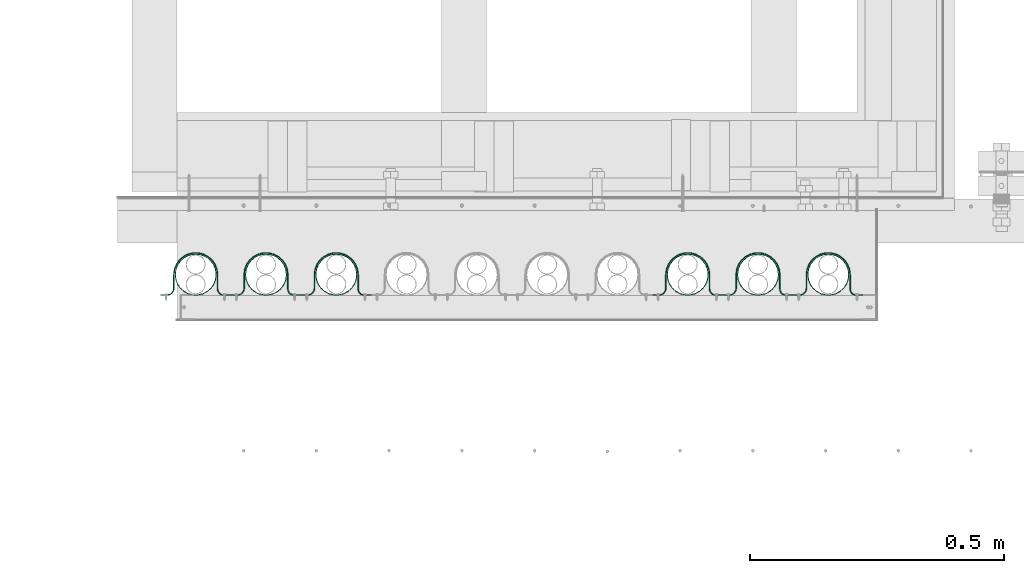
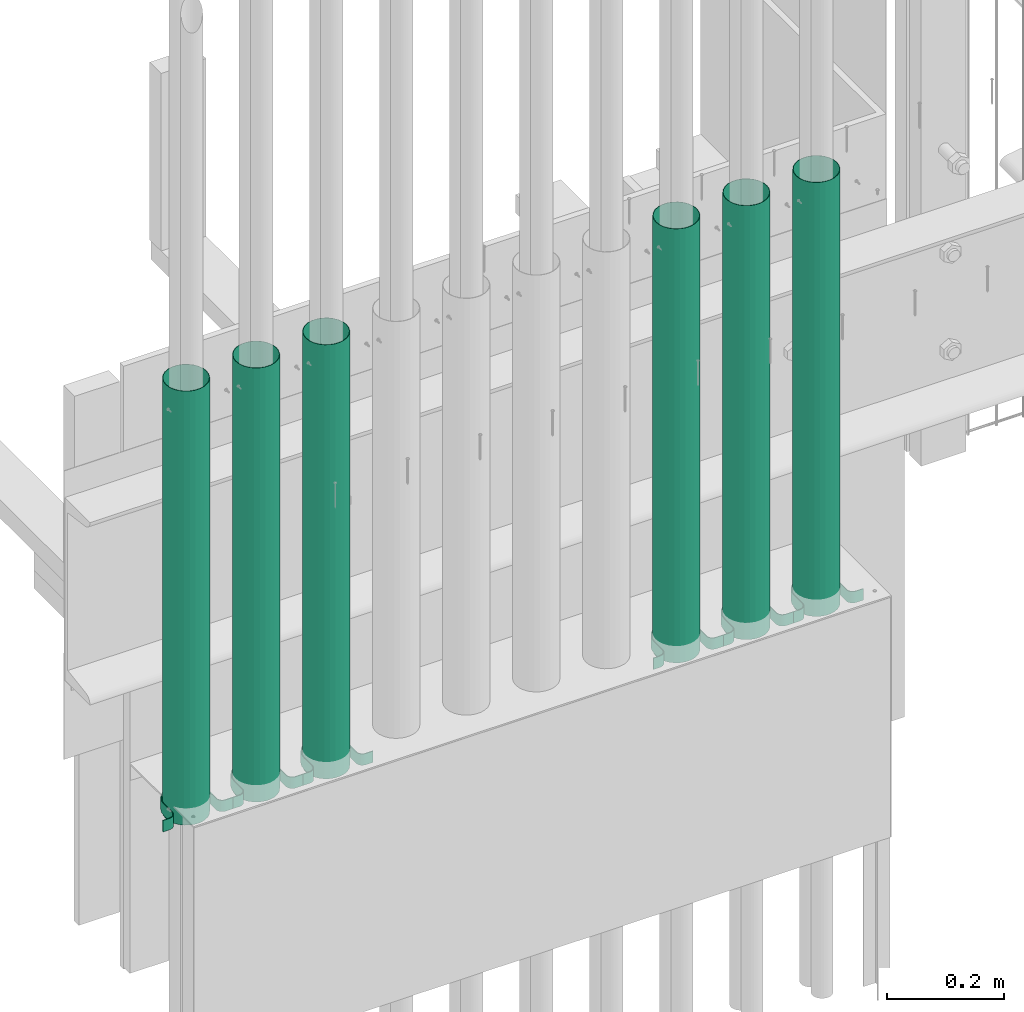
# One storey, part 7 of 44: 6 pipe fittings, 6 valves.
"""IFC4 building model written with IfcOpenShell, lengths in feet."""

from ifc_helpers import new_model, entity, si_unit, converted_unit, derived_unit, direction, frame, frame_2d, origin, place, context, subcontext, project, spatial, polyline, circle_curve, parameter, trimmed, segment, composite_curve, hollow_circle, outline, extrude, source, transform, mapped, material, type_object, type_shapes, element, save


model = new_model("IFC4")

# Units and contexts
model_context = context("Model", 3, precision=0.0001, world=origin(), true_north=direction((6.12303176911189e-17, 1.0)))
body_context = subcontext(model_context, "Body", "Model", "MODEL_VIEW")
ifc_project = project(units=[converted_unit("LENGTHUNIT", "FOOT", entity("IfcRatioMeasure", 0.3048), si_unit("LENGTHUNIT", "METRE"), dimensions=[1, 0, 0, 0, 0, 0, 0]), converted_unit("AREAUNIT", "SQUARE FOOT", entity("IfcRatioMeasure", 0.09290304), si_unit("AREAUNIT", "SQUARE_METRE"), dimensions=[2, 0, 0, 0, 0, 0, 0]), converted_unit("VOLUMEUNIT", "CUBIC FOOT", entity("IfcRatioMeasure", 0.028316846592), si_unit("VOLUMEUNIT", "CUBIC_METRE"), dimensions=[3, 0, 0, 0, 0, 0, 0]), converted_unit("PLANEANGLEUNIT", "DEGREE", entity("IfcRatioMeasure", 0.0174532925199433), si_unit("PLANEANGLEUNIT", "RADIAN"), dimensions=[0, 0, 0, 0, 0, 0, 0]), si_unit("MASSUNIT", "GRAM", prefix="KILO"), derived_unit("MASSDENSITYUNIT", [(si_unit("MASSUNIT", "GRAM", prefix="KILO"), 1), (si_unit("LENGTHUNIT", "METRE"), -3)]), derived_unit("MOMENTOFINERTIAUNIT", [(si_unit("LENGTHUNIT", "METRE"), 4)]), si_unit("TIMEUNIT", "SECOND"), si_unit("FREQUENCYUNIT", "HERTZ"), si_unit("THERMODYNAMICTEMPERATUREUNIT", "DEGREE_CELSIUS"), derived_unit("THERMALTRANSMITTANCEUNIT", [(si_unit("MASSUNIT", "GRAM", prefix="KILO"), 1), (si_unit("THERMODYNAMICTEMPERATUREUNIT", "KELVIN"), -1), (si_unit("TIMEUNIT", "SECOND"), -3)]), derived_unit("VOLUMETRICFLOWRATEUNIT", [(si_unit("LENGTHUNIT", "METRE"), 3), (si_unit("TIMEUNIT", "SECOND"), -1)]), si_unit("ELECTRICCURRENTUNIT", "AMPERE"), si_unit("ELECTRICVOLTAGEUNIT", "VOLT"), si_unit("POWERUNIT", "WATT"), si_unit("FORCEUNIT", "NEWTON"), si_unit("ILLUMINANCEUNIT", "LUX"), si_unit("LUMINOUSFLUXUNIT", "LUMEN"), si_unit("LUMINOUSINTENSITYUNIT", "CANDELA"), derived_unit("USERDEFINED", [(si_unit("MASSUNIT", "GRAM", prefix="KILO"), -1), (si_unit("LENGTHUNIT", "METRE"), -2), (si_unit("TIMEUNIT", "SECOND"), 3), (si_unit("LUMINOUSFLUXUNIT", "LUMEN"), 1)]), derived_unit("LINEARVELOCITYUNIT", [(si_unit("LENGTHUNIT", "METRE"), 1), (si_unit("TIMEUNIT", "SECOND"), -1)]), si_unit("PRESSUREUNIT", "PASCAL"), derived_unit("USERDEFINED", [(si_unit("LENGTHUNIT", "METRE"), -2), (si_unit("MASSUNIT", "GRAM", prefix="KILO"), 1), (si_unit("TIMEUNIT", "SECOND"), -2)]), derived_unit("LINEARFORCEUNIT", [(si_unit("MASSUNIT", "GRAM", prefix="KILO"), 1), (si_unit("LENGTHUNIT", "METRE"), 1), (si_unit("TIMEUNIT", "SECOND"), -2), (si_unit("LENGTHUNIT", "METRE"), -1)]), derived_unit("PLANARFORCEUNIT", [(si_unit("MASSUNIT", "GRAM", prefix="KILO"), 1), (si_unit("LENGTHUNIT", "METRE"), 1), (si_unit("TIMEUNIT", "SECOND"), -2), (si_unit("LENGTHUNIT", "METRE"), -2)])], contexts=[model_context])

# Site, building, storey
site_placement = place(None, origin())
site = spatial("IfcSite", under=ifc_project, at=site_placement, CompositionType="ELEMENT")
building_placement = place(site_placement, origin())
building = spatial("IfcBuilding", under=site, at=building_placement, CompositionType="ELEMENT")
storey_placement = place(building_placement, origin())
storey = spatial("IfcBuildingStorey", under=building, at=storey_placement, CompositionType="ELEMENT", Elevation=0.0)

# Pipe fitting
ifc_material_1 = material(Name="GALV. PIPE", Category="Materials")
pipe_fitting_type_1 = type_object("IfcPipeFittingType", Name="Pipe1:Pipe", PredefinedType="NOTDEFINED", material=ifc_material_1)
shared_shape_1 = source(origin(), body_context, "Body", "SweptSolid", [
    extrude(hollow_circle(Radius=0.133196488133789, WallThickness=0.00260416666666666, at=frame_2d((2.91529109135044e-30, -8.88178419700125e-16), x_axis=(1.0, 0.0))), frame((0.138430320928819, 0.138430320928789, 0.0)), (0.0, 0.0, 1.0), 2.97420597925747),
])
type_shapes(pipe_fitting_type_1, [shared_shape_1])
pipe_fitting_1_placement = place(storey_placement, frame((1490.94496308898, 4.11247536199349, 7.88838525934749)))
element("IfcPipeFitting", 1, at=pipe_fitting_1_placement, inside=storey, type_object=pipe_fitting_type_1, material=ifc_material_1, Name="Pipe1:Pipe", ObjectType="Pipe1:Pipe", PredefinedType="NOTDEFINED", context=body_context, shape_type="MappedRepresentation", body=[
    mapped(shared_shape_1, transform((0.0, 0.0, 0.0), scale=1.0)),
])

# Valve
ifc_material_2 = material(Name="GALV. U BRACKET AT GALV. PIPE", Category="Materials")
valve_type_1 = type_object("IfcValveType", Name="U BRACKET1:U BRACKET", PredefinedType="NOTDEFINED", material=ifc_material_2)
shared_shape_2 = source(origin(), body_context, "Body", "SweptSolid", [
    extrude(outline(composite_curve([segment(polyline([(0.0407648216664178, -0.226295029472567), (0.0459731549997509, -0.226295029472567)]), True, "CONTINUOUS"), segment(polyline([(0.0459731549997509, -0.226295029472567), (0.0459731549997509, -0.184628362805825)]), True, "CONTINUOUS"), segment(trimmed(circle_curve(frame_2d((-0.000901845000249146, -0.184628362805825), x_axis=(0.0, 1.0)), 0.046875), [parameter(270.0)], [parameter(2.03555499613665e-13)], True, "PARAMETER"), True, "CONTINUOUS"), segment(polyline([(-0.000901845000249146, -0.137753362805825), (-0.0884402983327055, -0.137753362805825)]), True, "CONTINUOUS"), segment(trimmed(circle_curve(frame_2d((-0.0884402983327037, 0.000651041666515084), x_axis=(0.0, 1.0)), 0.138404404472415), [parameter(2.03555499613665e-13)], [parameter(180.0)], True, "PARAMETER"), False, "CONTINUOUS"), segment(polyline([(-0.0884402983327037, 0.139055446138855), (0.00430648833316294, 0.139055446138855)]), True, "CONTINUOUS"), segment(trimmed(circle_curve(frame_2d((0.00430648833316294, 0.180722112805597), x_axis=(0.0, 1.0)), 0.0416666666666667), [parameter(180.0)], [parameter(270.0)], True, "PARAMETER"), True, "CONTINUOUS"), segment(polyline([(0.0459731549998299, 0.180722112805597), (0.0459731549998308, 0.227597112805597)]), True, "CONTINUOUS"), segment(polyline([(0.0459731549998308, 0.227597112805597), (0.0407648216664969, 0.227597112805597)]), True, "CONTINUOUS"), segment(polyline([(0.0407648216664969, 0.227597112805597), (0.0407648216664969, 0.180722112805597)]), True, "CONTINUOUS"), segment(trimmed(circle_curve(frame_2d((0.00430648833316294, 0.180722112805597), x_axis=(0.0, 1.0)), 0.0364583333333333), [parameter(180.0)], [parameter(270.0)], True, "PARAMETER"), False, "CONTINUOUS"), segment(polyline([(0.00430648833316294, 0.14426377947234), (-0.0884402983327028, 0.14426377947234)]), True, "CONTINUOUS"), segment(trimmed(circle_curve(frame_2d((-0.0884402983327037, 0.000651041666515084), x_axis=(0.0, 1.0)), 0.143612737805749), [parameter(360.0)], [parameter(180.0)], True, "PARAMETER"), True, "CONTINUOUS"), segment(polyline([(-0.0884402983327055, -0.142961696139309), (-0.000901845000249146, -0.142961696139309)]), True, "CONTINUOUS"), segment(trimmed(circle_curve(frame_2d((-0.000901845000249146, -0.184628362805825), x_axis=(0.0, 1.0)), 0.0416666666666667), [parameter(270.0)], [parameter(2.03555499613665e-13)], True, "PARAMETER"), False, "CONTINUOUS"), segment(polyline([(0.0407648216664178, -0.184628362805825), (0.0407648216664178, -0.226295029472567)]), True, "CONTINUOUS")], self_intersect=False)), frame((0.226295029472567, 0.0512069877948296, 0.0), z_axis=(0.0, 0.0, 1.0), x_axis=(0.0, -1.0, 0.0)), (0.0, 0.0, 1.0), 0.078003864882298),
])
type_shapes(valve_type_1, [shared_shape_2])
valve_1_placement = place(storey_placement, frame((1490.85644733877, 4.11092510371606, 7.91059739384998)))
element("IfcValve", 2, at=valve_1_placement, inside=storey, type_object=valve_type_1, material=ifc_material_2, Name="U BRACKET1:U BRACKET", ObjectType="U BRACKET1:U BRACKET", PredefinedType="NOTDEFINED", context=body_context, shape_type="MappedRepresentation", body=[
    mapped(shared_shape_2, transform((0.0, 0.0, 0.0), scale=1.0)),
])

# Pipe fitting
pipe_fitting_type_2 = type_object("IfcPipeFittingType", Name="Pipe3:Pipe", PredefinedType="NOTDEFINED", material=ifc_material_1)
shared_shape_3 = source(origin(), body_context, "Body", "SweptSolid", [
    extrude(hollow_circle(Radius=0.133196488133789, WallThickness=0.00260416666666666, at=frame_2d((-1.29196706982829e-30, -8.88178419700125e-16), x_axis=(1.0, 0.0))), frame((0.138430320928819, 0.138430320928789, 0.0)), (0.0, 0.0, 1.0), 2.97420597925747),
])
type_shapes(pipe_fitting_type_2, [shared_shape_3])
pipe_fitting_2_placement = place(storey_placement, frame((1491.39885523126, 4.11247536199348, 7.88838525934749)))
element("IfcPipeFitting", 3, at=pipe_fitting_2_placement, inside=storey, type_object=pipe_fitting_type_2, material=ifc_material_1, Name="Pipe3:Pipe", ObjectType="Pipe3:Pipe", PredefinedType="NOTDEFINED", context=body_context, shape_type="MappedRepresentation", body=[
    mapped(shared_shape_3, transform((0.0, 0.0, 0.0), scale=1.0)),
])

# Valve
valve_type_2 = type_object("IfcValveType", Name="U BRACKET4:U BRACKET", PredefinedType="NOTDEFINED", material=ifc_material_2)
shared_shape_4 = source(origin(), body_context, "Body", "SweptSolid", [
    extrude(outline(composite_curve([segment(polyline([(0.0407648216664178, -0.226295029472567), (0.0459731549997509, -0.226295029472567)]), True, "CONTINUOUS"), segment(polyline([(0.0459731549997509, -0.226295029472567), (0.0459731549997509, -0.184628362805825)]), True, "CONTINUOUS"), segment(trimmed(circle_curve(frame_2d((-0.000901845000249146, -0.184628362805825), x_axis=(0.0, 1.0)), 0.046875), [parameter(270.0)], [parameter(2.03555499613665e-13)], True, "PARAMETER"), True, "CONTINUOUS"), segment(polyline([(-0.000901845000249146, -0.137753362805825), (-0.0884402983327055, -0.137753362805825)]), True, "CONTINUOUS"), segment(trimmed(circle_curve(frame_2d((-0.0884402983327037, 0.000651041666515084), x_axis=(0.0, 1.0)), 0.138404404472415), [parameter(2.03555499613665e-13)], [parameter(180.0)], True, "PARAMETER"), False, "CONTINUOUS"), segment(polyline([(-0.0884402983327037, 0.139055446138855), (0.00430648833316294, 0.139055446138855)]), True, "CONTINUOUS"), segment(trimmed(circle_curve(frame_2d((0.00430648833316294, 0.180722112805597), x_axis=(0.0, 1.0)), 0.0416666666666667), [parameter(180.0)], [parameter(270.0)], True, "PARAMETER"), True, "CONTINUOUS"), segment(polyline([(0.0459731549998299, 0.180722112805597), (0.0459731549998308, 0.227597112805597)]), True, "CONTINUOUS"), segment(polyline([(0.0459731549998308, 0.227597112805597), (0.0407648216664969, 0.227597112805597)]), True, "CONTINUOUS"), segment(polyline([(0.0407648216664969, 0.227597112805597), (0.0407648216664969, 0.180722112805597)]), True, "CONTINUOUS"), segment(trimmed(circle_curve(frame_2d((0.00430648833316294, 0.180722112805597), x_axis=(0.0, 1.0)), 0.0364583333333333), [parameter(180.0)], [parameter(270.0)], True, "PARAMETER"), False, "CONTINUOUS"), segment(polyline([(0.00430648833316294, 0.14426377947234), (-0.0884402983327028, 0.14426377947234)]), True, "CONTINUOUS"), segment(trimmed(circle_curve(frame_2d((-0.0884402983327037, 0.000651041666515084), x_axis=(0.0, 1.0)), 0.143612737805749), [parameter(360.0)], [parameter(180.0)], True, "PARAMETER"), True, "CONTINUOUS"), segment(polyline([(-0.0884402983327055, -0.142961696139309), (-0.000901845000249146, -0.142961696139309)]), True, "CONTINUOUS"), segment(trimmed(circle_curve(frame_2d((-0.000901845000249146, -0.184628362805825), x_axis=(0.0, 1.0)), 0.0416666666666667), [parameter(270.0)], [parameter(2.03555499613665e-13)], True, "PARAMETER"), False, "CONTINUOUS"), segment(polyline([(0.0407648216664178, -0.184628362805825), (0.0407648216664178, -0.226295029472567)]), True, "CONTINUOUS")], self_intersect=False)), frame((0.226295029472567, 0.0512069877948296, 0.0), z_axis=(0.0, 0.0, 1.0), x_axis=(0.0, -1.0, 0.0)), (0.0, 0.0, 1.0), 0.078003864882298),
])
type_shapes(valve_type_2, [shared_shape_4])
valve_2_placement = place(storey_placement, frame((1491.31033948105, 4.11092510371606, 7.91059739384999)))
element("IfcValve", 4, at=valve_2_placement, inside=storey, type_object=valve_type_2, material=ifc_material_2, Name="U BRACKET4:U BRACKET", ObjectType="U BRACKET4:U BRACKET", PredefinedType="NOTDEFINED", context=body_context, shape_type="MappedRepresentation", body=[
    mapped(shared_shape_4, transform((0.0, 0.0, 0.0), scale=1.0)),
])

# Pipe fitting
pipe_fitting_type_3 = type_object("IfcPipeFittingType", Name="Pipe5:Pipe", PredefinedType="NOTDEFINED", material=ifc_material_1)
shared_shape_5 = source(origin(), body_context, "Body", "SweptSolid", [
    extrude(hollow_circle(Radius=0.133196488133789, WallThickness=0.00260416666666666, at=frame_2d((2.91529109135044e-30, -8.88178419700125e-16), x_axis=(1.0, 0.0))), frame((0.138430320928819, 0.138430320928789, 0.0)), (0.0, 0.0, 1.0), 2.97420597925747),
])
type_shapes(pipe_fitting_type_3, [shared_shape_5])
pipe_fitting_3_placement = place(storey_placement, frame((1490.4910709467, 4.11247536199349, 7.88838525934748)))
element("IfcPipeFitting", 5, at=pipe_fitting_3_placement, inside=storey, type_object=pipe_fitting_type_3, material=ifc_material_1, Name="Pipe5:Pipe", ObjectType="Pipe5:Pipe", PredefinedType="NOTDEFINED", context=body_context, shape_type="MappedRepresentation", body=[
    mapped(shared_shape_5, transform((0.0, 0.0, 0.0), scale=1.0)),
])

# Valve
valve_type_3 = type_object("IfcValveType", Name="U BRACKET6:U BRACKET", PredefinedType="NOTDEFINED", material=ifc_material_2)
shared_shape_6 = source(origin(), body_context, "Body", "SweptSolid", [
    extrude(outline(composite_curve([segment(polyline([(0.0407648216664178, -0.226295029472567), (0.0459731549997509, -0.226295029472567)]), True, "CONTINUOUS"), segment(polyline([(0.0459731549997509, -0.226295029472567), (0.0459731549997509, -0.184628362805825)]), True, "CONTINUOUS"), segment(trimmed(circle_curve(frame_2d((-0.000901845000249146, -0.184628362805825), x_axis=(0.0, 1.0)), 0.046875), [parameter(270.0)], [parameter(2.03555499613665e-13)], True, "PARAMETER"), True, "CONTINUOUS"), segment(polyline([(-0.000901845000249146, -0.137753362805825), (-0.0884402983327046, -0.137753362805825)]), True, "CONTINUOUS"), segment(trimmed(circle_curve(frame_2d((-0.0884402983327037, 0.000651041666515084), x_axis=(0.0, 1.0)), 0.138404404472415), [parameter(2.03555499613665e-13)], [parameter(180.0)], True, "PARAMETER"), False, "CONTINUOUS"), segment(polyline([(-0.0884402983327037, 0.139055446138855), (0.00430648833316294, 0.139055446138855)]), True, "CONTINUOUS"), segment(trimmed(circle_curve(frame_2d((0.00430648833316294, 0.180722112805597), x_axis=(0.0, 1.0)), 0.0416666666666667), [parameter(180.0)], [parameter(270.0)], True, "PARAMETER"), True, "CONTINUOUS"), segment(polyline([(0.0459731549998299, 0.180722112805597), (0.0459731549998308, 0.227597112805597)]), True, "CONTINUOUS"), segment(polyline([(0.0459731549998308, 0.227597112805597), (0.0407648216664969, 0.227597112805597)]), True, "CONTINUOUS"), segment(polyline([(0.0407648216664969, 0.227597112805597), (0.0407648216664969, 0.180722112805597)]), True, "CONTINUOUS"), segment(trimmed(circle_curve(frame_2d((0.00430648833316294, 0.180722112805597), x_axis=(0.0, 1.0)), 0.0364583333333333), [parameter(180.0)], [parameter(270.0)], True, "PARAMETER"), False, "CONTINUOUS"), segment(polyline([(0.00430648833316294, 0.14426377947234), (-0.0884402983327028, 0.14426377947234)]), True, "CONTINUOUS"), segment(trimmed(circle_curve(frame_2d((-0.0884402983327037, 0.000651041666515084), x_axis=(0.0, 1.0)), 0.143612737805749), [parameter(360.0)], [parameter(180.0)], True, "PARAMETER"), True, "CONTINUOUS"), segment(polyline([(-0.0884402983327055, -0.142961696139309), (-0.000901845000249146, -0.142961696139309)]), True, "CONTINUOUS"), segment(trimmed(circle_curve(frame_2d((-0.000901845000249146, -0.184628362805825), x_axis=(0.0, 1.0)), 0.0416666666666667), [parameter(270.0)], [parameter(2.03555499613665e-13)], True, "PARAMETER"), False, "CONTINUOUS"), segment(polyline([(0.0407648216664178, -0.184628362805825), (0.0407648216664178, -0.226295029472567)]), True, "CONTINUOUS")], self_intersect=False)), frame((0.226295029472567, 0.0512069877948296, 0.0), z_axis=(0.0, 0.0, 1.0), x_axis=(0.0, -1.0, 0.0)), (0.0, 0.0, 1.0), 0.078003864882298),
])
type_shapes(valve_type_3, [shared_shape_6])
valve_3_placement = place(storey_placement, frame((1490.40255519649, 4.11092510371606, 7.91059739384998)))
element("IfcValve", 6, at=valve_3_placement, inside=storey, type_object=valve_type_3, material=ifc_material_2, Name="U BRACKET6:U BRACKET", ObjectType="U BRACKET6:U BRACKET", PredefinedType="NOTDEFINED", context=body_context, shape_type="MappedRepresentation", body=[
    mapped(shared_shape_6, transform((0.0, 0.0, 0.0), scale=1.0)),
])

# Pipe fitting
pipe_fitting_type_4 = type_object("IfcPipeFittingType", Name="Pipe15:Pipe", PredefinedType="NOTDEFINED", material=ifc_material_1)
shared_shape_7 = source(origin(), body_context, "Body", "SweptSolid", [
    extrude(hollow_circle(Radius=0.133196488133789, WallThickness=0.00260416666666666, at=frame_2d((2.91529109135044e-30, -8.88178419700125e-16), x_axis=(1.0, 0.0))), frame((0.138430320928819, 0.138430320928789, 0.0)), (0.0, 0.0, 1.0), 2.97420597925747),
])
type_shapes(pipe_fitting_type_4, [shared_shape_7])
pipe_fitting_4_placement = place(storey_placement, frame((1488.22161023531, 4.1124753619935, 7.88838525934747)))
element("IfcPipeFitting", 7, at=pipe_fitting_4_placement, inside=storey, type_object=pipe_fitting_type_4, material=ifc_material_1, Name="Pipe15:Pipe", ObjectType="Pipe15:Pipe", PredefinedType="NOTDEFINED", context=body_context, shape_type="MappedRepresentation", body=[
    mapped(shared_shape_7, transform((0.0, 0.0, 0.0), scale=1.0)),
])

# Valve
valve_type_4 = type_object("IfcValveType", Name="U BRACKET16:U BRACKET", PredefinedType="NOTDEFINED", material=ifc_material_2)
shared_shape_8 = source(origin(), body_context, "Body", "SweptSolid", [
    extrude(outline(composite_curve([segment(polyline([(0.0407648216664178, -0.226295029472567), (0.0459731549997509, -0.226295029472567)]), True, "CONTINUOUS"), segment(polyline([(0.0459731549997509, -0.226295029472567), (0.0459731549997509, -0.184628362805825)]), True, "CONTINUOUS"), segment(trimmed(circle_curve(frame_2d((-0.000901845000249146, -0.184628362805825), x_axis=(0.0, 1.0)), 0.046875), [parameter(270.0)], [parameter(2.03555499613665e-13)], True, "PARAMETER"), True, "CONTINUOUS"), segment(polyline([(-0.000901845000249146, -0.137753362805825), (-0.0884402983327055, -0.137753362805825)]), True, "CONTINUOUS"), segment(trimmed(circle_curve(frame_2d((-0.0884402983327037, 0.000651041666515084), x_axis=(0.0, 1.0)), 0.138404404472415), [parameter(2.03555499613665e-13)], [parameter(180.0)], True, "PARAMETER"), False, "CONTINUOUS"), segment(polyline([(-0.0884402983327037, 0.139055446138855), (0.00430648833316294, 0.139055446138855)]), True, "CONTINUOUS"), segment(trimmed(circle_curve(frame_2d((0.00430648833316294, 0.180722112805597), x_axis=(0.0, 1.0)), 0.0416666666666667), [parameter(180.0)], [parameter(270.0)], True, "PARAMETER"), True, "CONTINUOUS"), segment(polyline([(0.0459731549998299, 0.180722112805597), (0.0459731549998308, 0.227597112805597)]), True, "CONTINUOUS"), segment(polyline([(0.0459731549998308, 0.227597112805597), (0.0407648216664969, 0.227597112805597)]), True, "CONTINUOUS"), segment(polyline([(0.0407648216664969, 0.227597112805597), (0.0407648216664969, 0.180722112805597)]), True, "CONTINUOUS"), segment(trimmed(circle_curve(frame_2d((0.00430648833316294, 0.180722112805597), x_axis=(0.0, 1.0)), 0.0364583333333333), [parameter(180.0)], [parameter(270.0)], True, "PARAMETER"), False, "CONTINUOUS"), segment(polyline([(0.00430648833316294, 0.14426377947234), (-0.0884402983327028, 0.14426377947234)]), True, "CONTINUOUS"), segment(trimmed(circle_curve(frame_2d((-0.0884402983327037, 0.000651041666515084), x_axis=(0.0, 1.0)), 0.143612737805749), [parameter(360.0)], [parameter(180.0)], True, "PARAMETER"), True, "CONTINUOUS"), segment(polyline([(-0.0884402983327055, -0.142961696139309), (-0.000901845000249146, -0.142961696139309)]), True, "CONTINUOUS"), segment(trimmed(circle_curve(frame_2d((-0.000901845000249146, -0.184628362805825), x_axis=(0.0, 1.0)), 0.0416666666666667), [parameter(270.0)], [parameter(2.03555499613665e-13)], True, "PARAMETER"), False, "CONTINUOUS"), segment(polyline([(0.0407648216664178, -0.184628362805825), (0.0407648216664178, -0.226295029472567)]), True, "CONTINUOUS")], self_intersect=False)), frame((0.226295029472567, 0.0512069877948296, 0.0), z_axis=(0.0, 0.0, 1.0), x_axis=(0.0, -1.0, 0.0)), (0.0, 0.0, 1.0), 0.0780038648822954),
])
type_shapes(valve_type_4, [shared_shape_8])
valve_4_placement = place(storey_placement, frame((1488.1330944851, 4.11092510371608, 7.91059739384998)))
element("IfcValve", 8, at=valve_4_placement, inside=storey, type_object=valve_type_4, material=ifc_material_2, Name="U BRACKET16:U BRACKET", ObjectType="U BRACKET16:U BRACKET", PredefinedType="NOTDEFINED", context=body_context, shape_type="MappedRepresentation", body=[
    mapped(shared_shape_8, transform((0.0, 0.0, 0.0), scale=1.0)),
])

# Pipe fitting
pipe_fitting_type_5 = type_object("IfcPipeFittingType", Name="Pipe17:Pipe", PredefinedType="NOTDEFINED", material=ifc_material_1)
shared_shape_9 = source(origin(), body_context, "Body", "SweptSolid", [
    extrude(hollow_circle(Radius=0.133196488133789, WallThickness=0.00260416666666666, at=frame_2d((2.91529109135044e-30, -8.88178419700125e-16), x_axis=(1.0, 0.0))), frame((0.138430320928819, 0.138430320928789, 0.0)), (0.0, 0.0, 1.0), 2.97420597925747),
])
type_shapes(pipe_fitting_type_5, [shared_shape_9])
pipe_fitting_5_placement = place(storey_placement, frame((1487.76771809303, 4.11247536199351, 7.88838525934747)))
element("IfcPipeFitting", 9, at=pipe_fitting_5_placement, inside=storey, type_object=pipe_fitting_type_5, material=ifc_material_1, Name="Pipe17:Pipe", ObjectType="Pipe17:Pipe", PredefinedType="NOTDEFINED", context=body_context, shape_type="MappedRepresentation", body=[
    mapped(shared_shape_9, transform((0.0, 0.0, 0.0), scale=1.0)),
])

# Valve
valve_type_5 = type_object("IfcValveType", Name="U BRACKET18:U BRACKET", PredefinedType="NOTDEFINED", material=ifc_material_2)
shared_shape_10 = source(origin(), body_context, "Body", "SweptSolid", [
    extrude(outline(composite_curve([segment(polyline([(0.0407648216664178, -0.226295029472567), (0.0459731549997509, -0.226295029472567)]), True, "CONTINUOUS"), segment(polyline([(0.0459731549997509, -0.226295029472567), (0.0459731549997509, -0.184628362805825)]), True, "CONTINUOUS"), segment(trimmed(circle_curve(frame_2d((-0.000901845000249146, -0.184628362805825), x_axis=(0.0, 1.0)), 0.046875), [parameter(270.0)], [parameter(2.03555499613665e-13)], True, "PARAMETER"), True, "CONTINUOUS"), segment(polyline([(-0.000901845000249146, -0.137753362805825), (-0.0884402983327055, -0.137753362805825)]), True, "CONTINUOUS"), segment(trimmed(circle_curve(frame_2d((-0.0884402983327037, 0.000651041666515084), x_axis=(0.0, 1.0)), 0.138404404472415), [parameter(2.03555499613665e-13)], [parameter(180.0)], True, "PARAMETER"), False, "CONTINUOUS"), segment(polyline([(-0.0884402983327037, 0.139055446138855), (0.00430648833316294, 0.139055446138855)]), True, "CONTINUOUS"), segment(trimmed(circle_curve(frame_2d((0.00430648833316294, 0.180722112805597), x_axis=(0.0, 1.0)), 0.0416666666666667), [parameter(180.0)], [parameter(270.0)], True, "PARAMETER"), True, "CONTINUOUS"), segment(polyline([(0.0459731549998299, 0.180722112805597), (0.0459731549998308, 0.227597112805597)]), True, "CONTINUOUS"), segment(polyline([(0.0459731549998308, 0.227597112805597), (0.0407648216664969, 0.227597112805597)]), True, "CONTINUOUS"), segment(polyline([(0.0407648216664969, 0.227597112805597), (0.0407648216664969, 0.180722112805597)]), True, "CONTINUOUS"), segment(trimmed(circle_curve(frame_2d((0.00430648833316294, 0.180722112805597), x_axis=(0.0, 1.0)), 0.0364583333333333), [parameter(180.0)], [parameter(270.0)], True, "PARAMETER"), False, "CONTINUOUS"), segment(polyline([(0.00430648833316294, 0.14426377947234), (-0.0884402983327028, 0.14426377947234)]), True, "CONTINUOUS"), segment(trimmed(circle_curve(frame_2d((-0.0884402983327037, 0.000651041666515084), x_axis=(0.0, 1.0)), 0.143612737805749), [parameter(360.0)], [parameter(180.0)], True, "PARAMETER"), True, "CONTINUOUS"), segment(polyline([(-0.0884402983327055, -0.142961696139309), (-0.000901845000249146, -0.142961696139309)]), True, "CONTINUOUS"), segment(trimmed(circle_curve(frame_2d((-0.000901845000249146, -0.184628362805825), x_axis=(0.0, 1.0)), 0.0416666666666667), [parameter(270.0)], [parameter(2.03555499613665e-13)], True, "PARAMETER"), False, "CONTINUOUS"), segment(polyline([(0.0407648216664178, -0.184628362805825), (0.0407648216664178, -0.226295029472567)]), True, "CONTINUOUS")], self_intersect=False)), frame((0.226295029472567, 0.0512069877948296, 0.0), z_axis=(0.0, 0.0, 1.0), x_axis=(0.0, -1.0, 0.0)), (0.0, 0.0, 1.0), 0.0780038648822945),
])
type_shapes(valve_type_5, [shared_shape_10])
valve_5_placement = place(storey_placement, frame((1487.67920234282, 4.11092510371608, 7.91059739384998)))
element("IfcValve", 10, at=valve_5_placement, inside=storey, type_object=valve_type_5, material=ifc_material_2, Name="U BRACKET18:U BRACKET", ObjectType="U BRACKET18:U BRACKET", PredefinedType="NOTDEFINED", context=body_context, shape_type="MappedRepresentation", body=[
    mapped(shared_shape_10, transform((0.0, 0.0, 0.0), scale=1.0)),
])

# Pipe fitting
pipe_fitting_type_6 = type_object("IfcPipeFittingType", Name="Pipe19:Pipe", PredefinedType="NOTDEFINED", material=ifc_material_1)
shared_shape_11 = source(origin(), body_context, "Body", "SweptSolid", [
    extrude(hollow_circle(Radius=0.133196488133789, WallThickness=0.00260416666666666, at=frame_2d((2.91529109135044e-30, -8.88178419700125e-16), x_axis=(1.0, 0.0))), frame((0.138430320928819, 0.138430320928789, 0.0)), (0.0, 0.0, 1.0), 2.97420597925747),
])
type_shapes(pipe_fitting_type_6, [shared_shape_11])
pipe_fitting_6_placement = place(storey_placement, frame((1487.31382595075, 4.11247536199351, 7.88838525934747)))
element("IfcPipeFitting", 11, at=pipe_fitting_6_placement, inside=storey, type_object=pipe_fitting_type_6, material=ifc_material_1, Name="Pipe19:Pipe", ObjectType="Pipe19:Pipe", PredefinedType="NOTDEFINED", context=body_context, shape_type="MappedRepresentation", body=[
    mapped(shared_shape_11, transform((0.0, 0.0, 0.0), scale=1.0)),
])

# Valve
valve_type_6 = type_object("IfcValveType", Name="U BRACKET20:U BRACKET", PredefinedType="NOTDEFINED", material=ifc_material_2)
shared_shape_12 = source(origin(), body_context, "Body", "SweptSolid", [
    extrude(outline(composite_curve([segment(polyline([(0.0407648216664178, -0.226295029472567), (0.0459731549997509, -0.226295029472567)]), True, "CONTINUOUS"), segment(polyline([(0.0459731549997509, -0.226295029472567), (0.0459731549997509, -0.184628362805825)]), True, "CONTINUOUS"), segment(trimmed(circle_curve(frame_2d((-0.000901845000249146, -0.184628362805825), x_axis=(0.0, 1.0)), 0.046875), [parameter(270.0)], [parameter(2.03555499613665e-13)], True, "PARAMETER"), True, "CONTINUOUS"), segment(polyline([(-0.000901845000249146, -0.137753362805825), (-0.0884402983327055, -0.137753362805825)]), True, "CONTINUOUS"), segment(trimmed(circle_curve(frame_2d((-0.0884402983327037, 0.000651041666515084), x_axis=(0.0, 1.0)), 0.138404404472415), [parameter(2.03555499613665e-13)], [parameter(180.0)], True, "PARAMETER"), False, "CONTINUOUS"), segment(polyline([(-0.0884402983327037, 0.139055446138855), (0.00430648833316294, 0.139055446138855)]), True, "CONTINUOUS"), segment(trimmed(circle_curve(frame_2d((0.00430648833316294, 0.180722112805597), x_axis=(0.0, 1.0)), 0.0416666666666667), [parameter(180.0)], [parameter(270.0)], True, "PARAMETER"), True, "CONTINUOUS"), segment(polyline([(0.0459731549998299, 0.180722112805597), (0.0459731549998308, 0.227597112805597)]), True, "CONTINUOUS"), segment(polyline([(0.0459731549998308, 0.227597112805597), (0.0407648216664969, 0.227597112805597)]), True, "CONTINUOUS"), segment(polyline([(0.0407648216664969, 0.227597112805597), (0.0407648216664969, 0.180722112805597)]), True, "CONTINUOUS"), segment(trimmed(circle_curve(frame_2d((0.00430648833316294, 0.180722112805597), x_axis=(0.0, 1.0)), 0.0364583333333333), [parameter(180.0)], [parameter(270.0)], True, "PARAMETER"), False, "CONTINUOUS"), segment(polyline([(0.00430648833316294, 0.14426377947234), (-0.0884402983327028, 0.14426377947234)]), True, "CONTINUOUS"), segment(trimmed(circle_curve(frame_2d((-0.0884402983327037, 0.000651041666515084), x_axis=(0.0, 1.0)), 0.143612737805749), [parameter(360.0)], [parameter(180.0)], True, "PARAMETER"), True, "CONTINUOUS"), segment(polyline([(-0.0884402983327055, -0.142961696139309), (-0.000901845000249146, -0.142961696139309)]), True, "CONTINUOUS"), segment(trimmed(circle_curve(frame_2d((-0.000901845000249146, -0.184628362805825), x_axis=(0.0, 1.0)), 0.0416666666666667), [parameter(270.0)], [parameter(2.03555499613665e-13)], True, "PARAMETER"), False, "CONTINUOUS"), segment(polyline([(0.0407648216664178, -0.184628362805825), (0.0407648216664178, -0.226295029472567)]), True, "CONTINUOUS")], self_intersect=False)), frame((0.226295029472567, 0.0512069877948296, 0.0), z_axis=(0.0, 0.0, 1.0), x_axis=(0.0, -1.0, 0.0)), (0.0, 0.0, 1.0), 0.0780038648822936),
])
type_shapes(valve_type_6, [shared_shape_12])
valve_6_placement = place(storey_placement, frame((1487.22531020054, 4.11092510371608, 7.91059739384998)))
element("IfcValve", 12, at=valve_6_placement, inside=storey, type_object=valve_type_6, material=ifc_material_2, Name="U BRACKET20:U BRACKET", ObjectType="U BRACKET20:U BRACKET", PredefinedType="NOTDEFINED", context=body_context, shape_type="MappedRepresentation", body=[
    mapped(shared_shape_12, transform((0.0, 0.0, 0.0), scale=1.0)),
])

save(model, "model.ifc")
